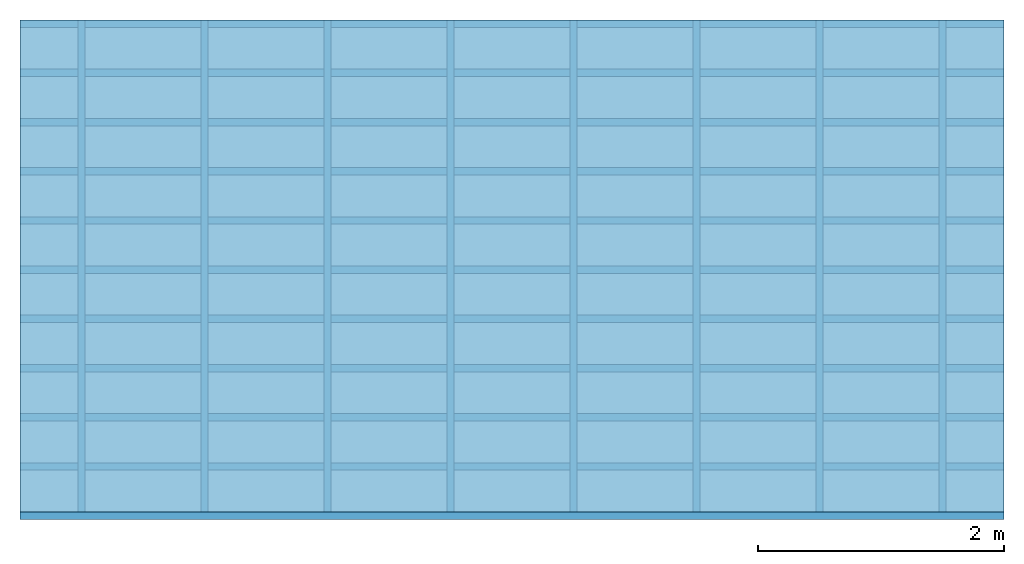
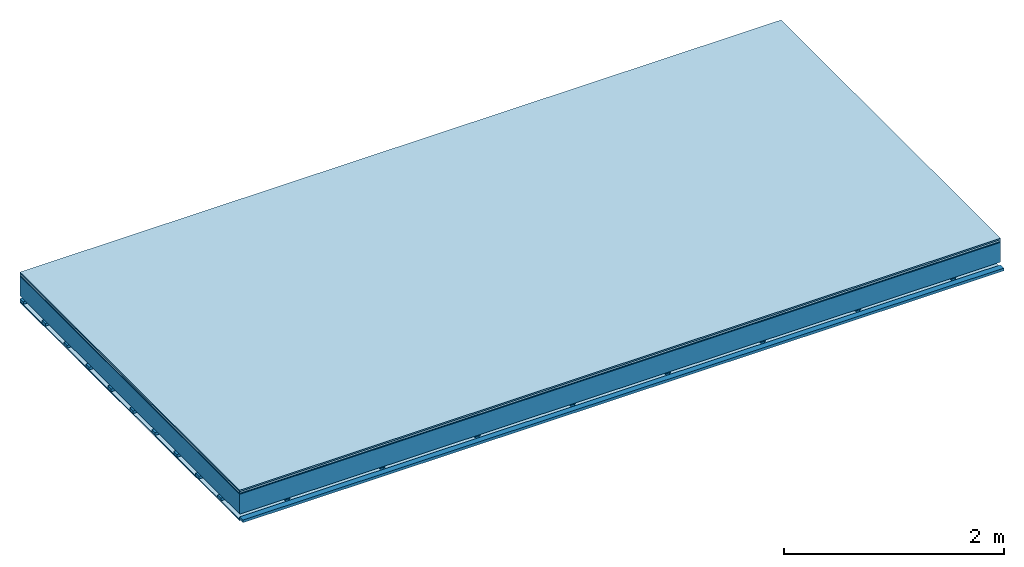
# One storey: 5 plates, 3 members, 1 element without a shape of its own.
"""IFC4 building model written with IfcOpenShell, lengths in metres."""

from ifc_helpers import new_model, si_unit, derived_unit, direction, frame, frame_2d, origin, origin_with_axes, place, context, project, spatial, polyline, rectangle, outline, extrude, material, layer, layer_set, type_object, element, aggregate, save


model = new_model("IFC4")

# Units and contexts
plan_context = context("Plan", 3, precision=1e-05, world=origin(), true_north=direction((0.0, 1.0)))
model_context = context("Model", 3, precision=1e-05, world=origin(), true_north=direction((0.0, 1.0)))
ifc_project = project(units=[si_unit("LENGTHUNIT", "METRE"), derived_unit("SOUNDPRESSUREUNIT", [(si_unit("PRESSUREUNIT", "PASCAL", prefix="MICRO"), 0)]), si_unit("ENERGYUNIT", "JOULE", prefix="MEGA"), si_unit("MASSUNIT", "GRAM", prefix="KILO"), derived_unit("THERMALTRANSMITTANCEUNIT", [(si_unit("POWERUNIT", "WATT"), 1), (si_unit("AREAUNIT", "SQUARE_METRE"), -1), (si_unit("THERMODYNAMICTEMPERATUREUNIT", "KELVIN"), -1)]), derived_unit("AREADENSITYUNIT", [(si_unit("MASSUNIT", "GRAM", prefix="KILO"), 1), (si_unit("AREAUNIT", "SQUARE_METRE"), -1)]), derived_unit("USERDEFINED", [(si_unit("ENERGYUNIT", "JOULE", prefix="MEGA"), 1), (si_unit("AREAUNIT", "SQUARE_METRE"), -1)])], contexts=[plan_context, model_context])

# Site, building, storey
site = spatial("IfcSite", under=ifc_project)
building_placement = place(None, origin())
building = spatial("IfcBuilding", under=site, at=building_placement)
storey_placement = place(building_placement, origin())
storey = spatial("IfcBuildingStorey", under=building, at=storey_placement)

# Slab, members, plates
ifc_material_1 = material(Category="11.013")
ifc_layer_1 = layer(ifc_material_1, 0.015, Name="Flooring")
ifc_material_2 = material(Category="03.007")
ifc_layer_2 = layer(ifc_material_2, 0.02, Name="On-material")
ifc_material_3 = material(Name="Wood fiber generic product", Category="10.009")
ifc_layer_3 = layer(ifc_material_3, 0.01, Name="Impact sound insulation")
ifc_material_4 = material(Name="no composite action")
ifc_layer_4 = layer(ifc_material_4, 0.0, Name="Bond")
ifc_layer_5 = layer(None, 0.22, Name="Supporting structure")
ifc_layer_6 = layer(ifc_material_4, 0.0, Name="Bond")
ifc_layer_7 = layer(None, 0.03, Name="Coupling")
ifc_layer_8 = layer(None, 0.03, Name="Battens / profiles")
ifc_material_5 = material(Name="Plasterboard type A", Category="03.008")
ifc_layer_9 = layer(ifc_material_5, 0.0125, Name="Ceiling covering 1st layer")
ifc_material_6 = material(Category="04.001")
ifc_layer_10 = layer(ifc_material_6, 0.003, Name="Surface / treatment")
ifc_layer_set = layer_set([ifc_layer_1, ifc_layer_2, ifc_layer_3, ifc_layer_4, ifc_layer_5, ifc_layer_6, ifc_layer_7, ifc_layer_8, ifc_layer_9, ifc_layer_10])
slab_type = type_object("IfcSlabType", Name="A2101", PredefinedType="NOTDEFINED", material=ifc_layer_set)
slab_placement = place(None, frame((0.0, 0.0, 0.0), z_axis=(0.0, 0.0, -1.0), x_axis=(1.0, 0.0, 0.0)))
slab = element("IfcSlab", 1, at=slab_placement, inside=storey, type_object=slab_type, material=ifc_layer_set, Name="Slab #1")
ifc_material_7 = material(Name="Solid timber panel")
member_1_placement = place(slab_placement, origin())
member_1 = element("IfcMember", 2, at=member_1_placement, material=ifc_material_7, Name="Supporting structure", context=plan_context, shape_type="SweptSolid", body=[
    extrude(rectangle(XDim=1.0, YDim=0.22, at=frame_2d((0.5, 0.11), x_axis=(1.0, 0.0))), frame((0.0, 4.0, 0.045), z_axis=(0.0, -1.0, 0.0), x_axis=(1.0, 0.0, 0.0)), (0.0, 0.0, 1.0), 4.0),
    extrude(rectangle(XDim=1.0, YDim=0.22, at=frame_2d((0.5, 0.11), x_axis=(1.0, 0.0))), frame((1.0, 4.0, 0.045), z_axis=(0.0, -1.0, 0.0), x_axis=(1.0, 0.0, 0.0)), (0.0, 0.0, 1.0), 4.0),
    extrude(rectangle(XDim=1.0, YDim=0.22, at=frame_2d((0.5, 0.11), x_axis=(1.0, 0.0))), frame((2.0, 4.0, 0.045), z_axis=(0.0, -1.0, 0.0), x_axis=(1.0, 0.0, 0.0)), (0.0, 0.0, 1.0), 4.0),
    extrude(rectangle(XDim=1.0, YDim=0.22, at=frame_2d((0.5, 0.11), x_axis=(1.0, 0.0))), frame((3.0, 4.0, 0.045), z_axis=(0.0, -1.0, 0.0), x_axis=(1.0, 0.0, 0.0)), (0.0, 0.0, 1.0), 4.0),
    extrude(rectangle(XDim=1.0, YDim=0.22, at=frame_2d((0.5, 0.11), x_axis=(1.0, 0.0))), frame((4.0, 4.0, 0.045), z_axis=(0.0, -1.0, 0.0), x_axis=(1.0, 0.0, 0.0)), (0.0, 0.0, 1.0), 4.0),
    extrude(rectangle(XDim=1.0, YDim=0.22, at=frame_2d((0.5, 0.11), x_axis=(1.0, 0.0))), frame((5.0, 4.0, 0.045), z_axis=(0.0, -1.0, 0.0), x_axis=(1.0, 0.0, 0.0)), (0.0, 0.0, 1.0), 4.0),
    extrude(rectangle(XDim=1.0, YDim=0.22, at=frame_2d((0.5, 0.11), x_axis=(1.0, 0.0))), frame((6.0, 4.0, 0.045), z_axis=(0.0, -1.0, 0.0), x_axis=(1.0, 0.0, 0.0)), (0.0, 0.0, 1.0), 4.0),
    extrude(rectangle(XDim=1.0, YDim=0.22, at=frame_2d((0.5, 0.11), x_axis=(1.0, 0.0))), frame((7.0, 4.0, 0.045), z_axis=(0.0, -1.0, 0.0), x_axis=(1.0, 0.0, 0.0)), (0.0, 0.0, 1.0), 4.0),
])
ifc_material_8 = material()
member_2_placement = place(slab_placement, origin())
member_2 = element("IfcMember", 3, at=member_2_placement, material=ifc_material_8, Name="Coupling", context=plan_context, shape_type="SweptSolid", body=[
    extrude(outline(polyline([(0.0, 0.0), (0.06, 0.0), (0.04, 0.02), (0.02, 0.02), (0.0, 0.0)])), frame((0.47, 4.0, 0.275), z_axis=(0.0, -1.0, 0.0), x_axis=(1.0, 0.0, 0.0)), (0.0, 0.0, 1.0), 4.0),
    extrude(outline(polyline([(0.0, 0.0), (0.06, 0.0), (0.04, 0.02), (0.02, 0.02), (0.0, 0.0)])), frame((1.47, 4.0, 0.275), z_axis=(0.0, -1.0, 0.0), x_axis=(1.0, 0.0, 0.0)), (0.0, 0.0, 1.0), 4.0),
    extrude(outline(polyline([(0.0, 0.0), (0.06, 0.0), (0.04, 0.02), (0.02, 0.02), (0.0, 0.0)])), frame((2.47, 4.0, 0.275), z_axis=(0.0, -1.0, 0.0), x_axis=(1.0, 0.0, 0.0)), (0.0, 0.0, 1.0), 4.0),
    extrude(outline(polyline([(0.0, 0.0), (0.06, 0.0), (0.04, 0.02), (0.02, 0.02), (0.0, 0.0)])), frame((3.47, 4.0, 0.275), z_axis=(0.0, -1.0, 0.0), x_axis=(1.0, 0.0, 0.0)), (0.0, 0.0, 1.0), 4.0),
    extrude(outline(polyline([(0.0, 0.0), (0.06, 0.0), (0.04, 0.02), (0.02, 0.02), (0.0, 0.0)])), frame((4.47, 4.0, 0.275), z_axis=(0.0, -1.0, 0.0), x_axis=(1.0, 0.0, 0.0)), (0.0, 0.0, 1.0), 4.0),
    extrude(outline(polyline([(0.0, 0.0), (0.06, 0.0), (0.04, 0.02), (0.02, 0.02), (0.0, 0.0)])), frame((5.47, 4.0, 0.275), z_axis=(0.0, -1.0, 0.0), x_axis=(1.0, 0.0, 0.0)), (0.0, 0.0, 1.0), 4.0),
    extrude(outline(polyline([(0.0, 0.0), (0.06, 0.0), (0.04, 0.02), (0.02, 0.02), (0.0, 0.0)])), frame((6.47, 4.0, 0.275), z_axis=(0.0, -1.0, 0.0), x_axis=(1.0, 0.0, 0.0)), (0.0, 0.0, 1.0), 4.0),
    extrude(outline(polyline([(0.0, 0.0), (0.06, 0.0), (0.04, 0.02), (0.02, 0.02), (0.0, 0.0)])), frame((7.47, 4.0, 0.275), z_axis=(0.0, -1.0, 0.0), x_axis=(1.0, 0.0, 0.0)), (0.0, 0.0, 1.0), 4.0),
])
member_3_placement = place(slab_placement, origin())
member_3 = element("IfcMember", 4, at=member_3_placement, material=ifc_material_8, Name="Battens / profiles", context=plan_context, shape_type="SweptSolid", body=[
    extrude(rectangle(XDim=0.06, YDim=0.03, at=frame_2d((0.03, 0.015), x_axis=(1.0, 0.0))), frame((0.0, 0.0, 0.295), z_axis=(1.0, 0.0, 0.0), x_axis=(0.0, 1.0, 0.0)), (0.0, 0.0, 1.0), 8.0),
    extrude(rectangle(XDim=0.06, YDim=0.03, at=frame_2d((0.03, 0.015), x_axis=(1.0, 0.0))), frame((0.0, 0.4, 0.295), z_axis=(1.0, 0.0, 0.0), x_axis=(0.0, 1.0, 0.0)), (0.0, 0.0, 1.0), 8.0),
    extrude(rectangle(XDim=0.06, YDim=0.03, at=frame_2d((0.03, 0.015), x_axis=(1.0, 0.0))), frame((0.0, 0.8, 0.295), z_axis=(1.0, 0.0, 0.0), x_axis=(0.0, 1.0, 0.0)), (0.0, 0.0, 1.0), 8.0),
    extrude(rectangle(XDim=0.06, YDim=0.03, at=frame_2d((0.03, 0.015), x_axis=(1.0, 0.0))), frame((0.0, 1.2, 0.295), z_axis=(1.0, 0.0, 0.0), x_axis=(0.0, 1.0, 0.0)), (0.0, 0.0, 1.0), 8.0),
    extrude(rectangle(XDim=0.06, YDim=0.03, at=frame_2d((0.03, 0.015), x_axis=(1.0, 0.0))), frame((0.0, 1.6, 0.295), z_axis=(1.0, 0.0, 0.0), x_axis=(0.0, 1.0, 0.0)), (0.0, 0.0, 1.0), 8.0),
    extrude(rectangle(XDim=0.06, YDim=0.03, at=frame_2d((0.03, 0.015), x_axis=(1.0, 0.0))), frame((0.0, 2.0, 0.295), z_axis=(1.0, 0.0, 0.0), x_axis=(0.0, 1.0, 0.0)), (0.0, 0.0, 1.0), 8.0),
    extrude(rectangle(XDim=0.06, YDim=0.03, at=frame_2d((0.03, 0.015), x_axis=(1.0, 0.0))), frame((0.0, 2.4, 0.295), z_axis=(1.0, 0.0, 0.0), x_axis=(0.0, 1.0, 0.0)), (0.0, 0.0, 1.0), 8.0),
    extrude(rectangle(XDim=0.06, YDim=0.03, at=frame_2d((0.03, 0.015), x_axis=(1.0, 0.0))), frame((0.0, 2.8, 0.295), z_axis=(1.0, 0.0, 0.0), x_axis=(0.0, 1.0, 0.0)), (0.0, 0.0, 1.0), 8.0),
    extrude(rectangle(XDim=0.06, YDim=0.03, at=frame_2d((0.03, 0.015), x_axis=(1.0, 0.0))), frame((0.0, 3.2, 0.295), z_axis=(1.0, 0.0, 0.0), x_axis=(0.0, 1.0, 0.0)), (0.0, 0.0, 1.0), 8.0),
    extrude(rectangle(XDim=0.06, YDim=0.03, at=frame_2d((0.03, 0.015), x_axis=(1.0, 0.0))), frame((0.0, 3.6, 0.295), z_axis=(1.0, 0.0, 0.0), x_axis=(0.0, 1.0, 0.0)), (0.0, 0.0, 1.0), 8.0),
    extrude(rectangle(XDim=0.06, YDim=0.03, at=frame_2d((0.03, 0.015), x_axis=(1.0, 0.0))), frame((0.0, 4.0, 0.295), z_axis=(1.0, 0.0, 0.0), x_axis=(0.0, 1.0, 0.0)), (0.0, 0.0, 1.0), 8.0),
])
plate_1_placement = place(slab_placement, origin())
plate_1 = element("IfcPlate", 5, at=plate_1_placement, material=ifc_material_1, Name="Flooring", context=plan_context, shape_type="SweptSolid", body=[
    extrude(rectangle(XDim=8.0, YDim=4.0, at=frame_2d((4.0, 2.0), x_axis=(1.0, 0.0))), origin_with_axes(), (0.0, 0.0, 1.0), 0.015),
])
plate_2_placement = place(slab_placement, origin())
plate_2 = element("IfcPlate", 6, at=plate_2_placement, material=ifc_material_2, Name="On-material", context=plan_context, shape_type="SweptSolid", body=[
    extrude(rectangle(XDim=8.0, YDim=4.0, at=frame_2d((4.0, 2.0), x_axis=(1.0, 0.0))), frame((0.0, 0.0, 0.015), z_axis=(0.0, 0.0, 1.0), x_axis=(1.0, 0.0, 0.0)), (0.0, 0.0, 1.0), 0.02),
])
plate_3_placement = place(slab_placement, origin())
plate_3 = element("IfcPlate", 7, at=plate_3_placement, material=ifc_material_3, Name="Impact sound insulation", context=plan_context, shape_type="SweptSolid", body=[
    extrude(rectangle(XDim=8.0, YDim=4.0, at=frame_2d((4.0, 2.0), x_axis=(1.0, 0.0))), frame((0.0, 0.0, 0.035), z_axis=(0.0, 0.0, 1.0), x_axis=(1.0, 0.0, 0.0)), (0.0, 0.0, 1.0), 0.01),
])
plate_4_placement = place(slab_placement, origin())
plate_4 = element("IfcPlate", 8, at=plate_4_placement, material=ifc_material_5, Name="Ceiling covering 1st layer", context=plan_context, shape_type="SweptSolid", body=[
    extrude(rectangle(XDim=8.0, YDim=4.0, at=frame_2d((4.0, 2.0), x_axis=(1.0, 0.0))), frame((0.0, 0.0, 0.325), z_axis=(0.0, 0.0, 1.0), x_axis=(1.0, 0.0, 0.0)), (0.0, 0.0, 1.0), 0.0125),
])
plate_5_placement = place(slab_placement, origin())
plate_5 = element("IfcPlate", 9, at=plate_5_placement, material=ifc_material_6, Name="Surface / treatment", context=plan_context, shape_type="SweptSolid", body=[
    extrude(rectangle(XDim=8.0, YDim=4.0, at=frame_2d((4.0, 2.0), x_axis=(1.0, 0.0))), frame((0.0, 0.0, 0.3375), z_axis=(0.0, 0.0, 1.0), x_axis=(1.0, 0.0, 0.0)), (0.0, 0.0, 1.0), 0.003),
])
aggregate(slab, [plate_1, plate_2, plate_3, member_1, member_2, member_3, plate_4, plate_5])

save(model, "model.ifc")
